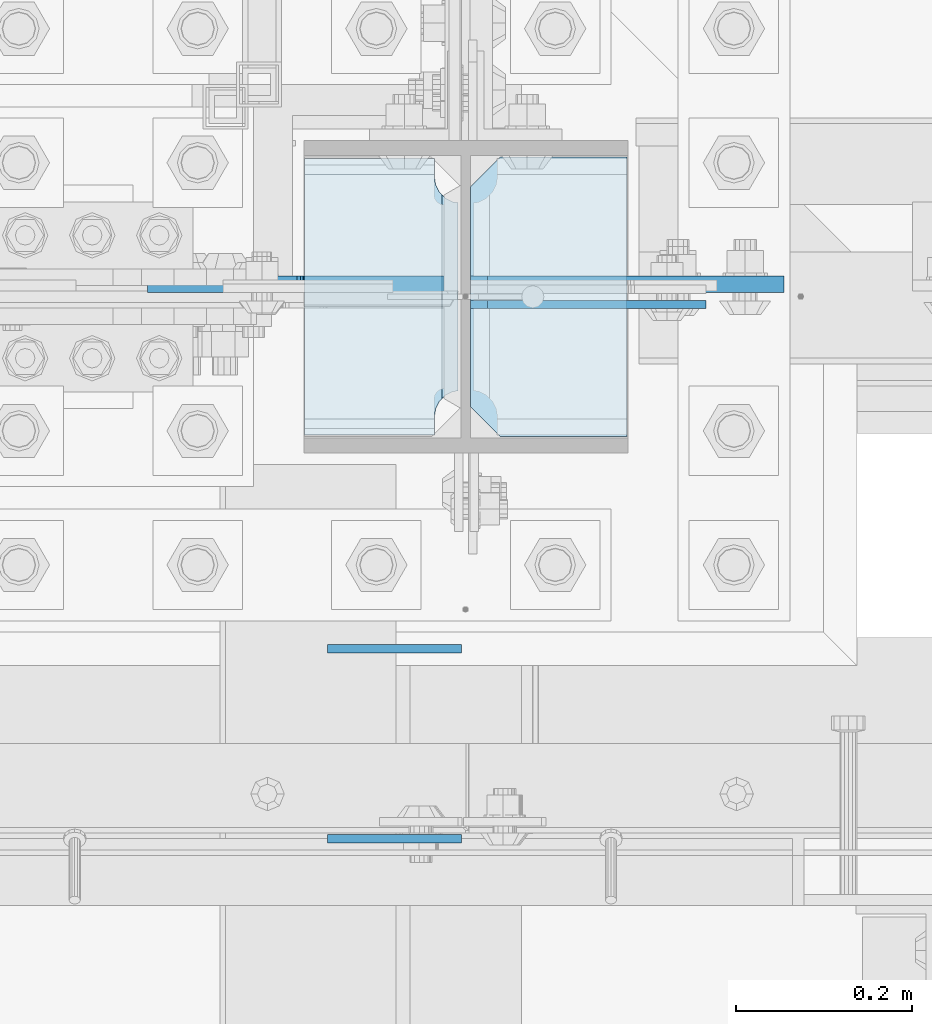
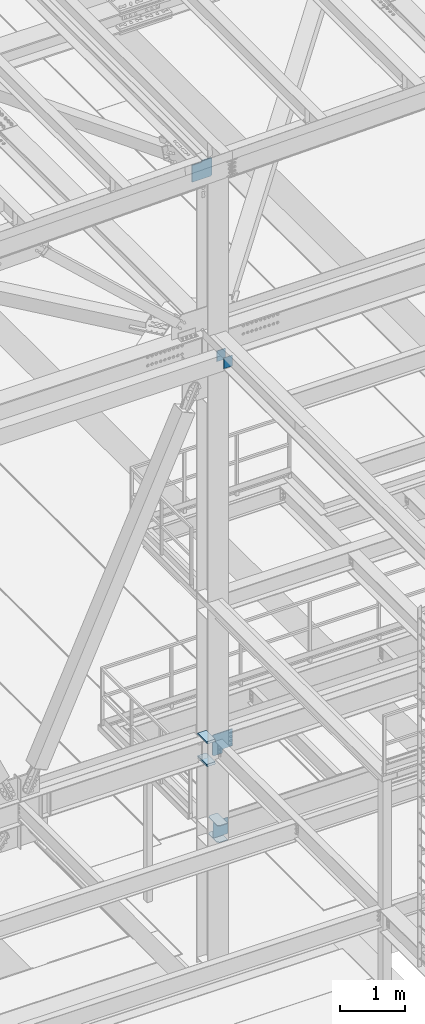
# One storey, part 3136 of 3843: 9 plates, 2 elements without a shape of their own.
"""IFC2X3 building model written with IfcOpenShell, lengths in millimetres."""

import ifcopenshell
import ifcopenshell.guid

model = None  # the IFC model being written
_history = None  # IfcOwnerHistory: only IFC2X3 demands one
_inside = {}  # id of a spatial element -> (the spatial element, [elements in it])
_under = {}  # id of a project, library or spatial element -> (it, [spatial elements below it])
_declared = {}  # id of a project -> (the project, [libraries it declares])
_typed = {}  # id of a type object -> (the type object, [elements of that type])
_made_of = {}  # id of a material, layer set ... -> (it, [elements and type objects made of it])


def new_model(schema):
    """Start an empty IFC model of exactly this schema.

    Asked for "IFC4X3", IfcOpenShell would pick the latest addendum, in which some entities
    have other attributes; the version numbers below select the first issue.
    IFC2X3 requires an IfcOwnerHistory on every rooted entity: one is made here for all.
    """
    global model, _history
    if schema == "IFC4X3":
        model = ifcopenshell.file(schema_version=(4, 3, 0, 0))
    else:
        model = ifcopenshell.file(schema=schema)
    _inside.clear()
    _under.clear()
    _declared.clear()
    _typed.clear()
    _made_of.clear()
    _history = None
    if model.schema == "IFC2X3":
        org = make("IfcOrganization", Name="unknown")
        user = make(
            "IfcPersonAndOrganization",
            ThePerson=make("IfcPerson", FamilyName="unknown"),
            TheOrganization=org,
        )
        app = make(
            "IfcApplication",
            ApplicationDeveloper=org,
            Version="unknown",
            ApplicationFullName="unknown",
            ApplicationIdentifier="unknown",
        )
        _history = make(
            "IfcOwnerHistory",
            OwningUser=user,
            OwningApplication=app,
            ChangeAction="ADDED",
            CreationDate=0,
        )
    return model


def make(cls, **values):
    """One entity of the class cls with the attributes given. An attribute that is None is left unset."""
    return model.create_entity(
        cls, **{name: value for name, value in values.items() if value is not None}
    )


def rooted(cls, **values):
    """An entity with a GlobalId (a new one), such as an element, a storey or a relation."""
    return make(cls, GlobalId=ifcopenshell.guid.new(), OwnerHistory=_history, **values)


def si_unit(unit_type, name, prefix=None):
    """IfcSIUnit, for example si_unit("LENGTHUNIT", "METRE", prefix="MILLI")."""
    return make("IfcSIUnit", UnitType=unit_type, Prefix=prefix, Name=name)


def assignment(units):
    """IfcUnitAssignment: the units of a project."""
    return None if units is None else make("IfcUnitAssignment", Units=units)


def point(xyz):
    """IfcCartesianPoint."""
    return None if xyz is None else make("IfcCartesianPoint", Coordinates=xyz)


def direction(xyz):
    """IfcDirection."""
    return None if xyz is None else make("IfcDirection", DirectionRatios=xyz)


def frame(location, z_axis=None, x_axis=None):
    """IfcAxis2Placement3D, a coordinate frame: its origin and axes. An axis left out is left unset."""
    return make(
        "IfcAxis2Placement3D",
        Location=point(location),
        Axis=direction(z_axis),
        RefDirection=direction(x_axis),
    )


def origin_with_axes():
    """The frame at (0, 0, 0) with the z axis (0, 0, 1) and the x axis (1, 0, 0) written out."""
    return frame((0.0, 0.0, 0.0), z_axis=(0.0, 0.0, 1.0), x_axis=(1.0, 0.0, 0.0))


def place(relative_to, where):
    """IfcLocalPlacement: puts the frame where relative to a parent placement (None: the world)."""
    return make(
        "IfcLocalPlacement", PlacementRelTo=relative_to, RelativePlacement=where
    )


def context(
    kind, dimensions, precision=None, world=None, true_north=None, identifier=None
):
    """IfcGeometricRepresentationContext, for example the 3D "Model" context."""
    return make(
        "IfcGeometricRepresentationContext",
        ContextIdentifier=identifier,
        ContextType=kind,
        CoordinateSpaceDimension=dimensions,
        Precision=precision,
        WorldCoordinateSystem=world,
        TrueNorth=true_north,
    )


def subcontext(parent, identifier, kind, view, scale=None):
    """IfcGeometricRepresentationSubContext, for example "Body" below "Model"."""
    return make(
        "IfcGeometricRepresentationSubContext",
        ContextIdentifier=identifier,
        ContextType=kind,
        ParentContext=parent,
        TargetScale=scale,
        TargetView=view,
    )


def project(units=None, contexts=None):
    """IfcProject with its units and contexts."""
    return rooted(
        "IfcProject",
        Name="project",
        RepresentationContexts=contexts,
        UnitsInContext=assignment(units),
    )


def spatial(cls, under=None, at=None, **own):
    """A site, building, storey or space (cls), placed at a placement, below another one or the project."""
    s = rooted(cls, ObjectPlacement=at, **own)
    if under is not None:
        _under.setdefault(under.id(), (under, []))[1].append(s)
    return s


def faces_of(points, faces, orient=None, outer=None):
    """IfcFace entities. A face is a list of loops; a loop is a list of indices into points, from 0.

    orient and outer hold one flag for each loop. By default every Orientation is true, the
    first loop of a face is its IfcFaceOuterBound and the others are IfcFaceBound.
    """
    made = []
    for i, loops in enumerate(faces):
        bounds = []
        for j, loop in enumerate(loops):
            is_outer = j == 0 if outer is None else outer[i][j]
            bounds.append(
                make(
                    "IfcFaceOuterBound" if is_outer else "IfcFaceBound",
                    Bound=make("IfcPolyLoop", Polygon=[points[k] for k in loop]),
                    Orientation=True if orient is None else orient[i][j],
                )
            )
        made.append(make("IfcFace", Bounds=bounds))
    return made


def faceted_brep(points, faces, orient=None, outer=None, voids=None):
    """IfcFacetedBrep: a solid bounded by flat faces; with voids (closed shells), ...WithVoids."""
    shared = [point(p) for p in points]
    hull = make("IfcClosedShell", CfsFaces=faces_of(shared, faces, orient, outer))
    if voids is None:
        return make("IfcFacetedBrep", Outer=hull)
    return make(
        "IfcFacetedBrepWithVoids",
        Outer=hull,
        Voids=[
            make(cls, CfsFaces=faces_of(shared, fs, o, b)) for cls, fs, o, b in voids
        ],
    )


def shape(context_of_items, identifier, shape_type, items):
    """IfcShapeRepresentation: the items that make up one representation, for example the "Body"."""
    return make(
        "IfcShapeRepresentation",
        ContextOfItems=context_of_items,
        RepresentationIdentifier=identifier,
        RepresentationType=shape_type,
        Items=items,
    )


def material(Name=None, Category=None):
    """IfcMaterial."""
    return make("IfcMaterial", Name=Name, Category=Category)


def made_of(thing, what):
    """Note that an element or type object is made of a material, layer set ...; save() writes the relation."""
    if what is not None:
        _made_of.setdefault(what.id(), (what, []))[1].append(thing)
    return thing


def type_object(cls, material=None, **own):
    """A type object (cls), such as IfcWallType, which elements share."""
    return made_of(rooted(cls, **own), material)


def element(
    cls,
    number,
    at=None,
    inside=None,
    cuts=None,
    type_object=None,
    material=None,
    context=None,
    identifier="Body",
    shape_type=None,
    held_by="IfcProductDefinitionShape",
    body=None,
    shapes=None,
    **own,
):
    """One element of the class cls, such as IfcWall. Its Tag is "e" and its number.

    at: its placement. inside: the storey or other place that contains it. cuts: it is an
    opening in that element (IfcRelVoidsElement). A single representation is given by context,
    identifier, shape_type and body (its items); several are given by shapes. held_by: the class
    of the entity that holds the representations. save() writes the other relations.
    """
    e = rooted(cls, Tag="e%d" % number, ObjectPlacement=at, **own)
    if body is not None:
        shapes = [shape(context, identifier, shape_type, body)]
    if shapes is not None:
        e.Representation = make(held_by, Representations=shapes)
    if inside is not None:
        _inside.setdefault(inside.id(), (inside, []))[1].append(e)
    if cuts is not None:
        rooted(
            "IfcRelVoidsElement", RelatingBuildingElement=cuts, RelatedOpeningElement=e
        )
    if type_object is not None:
        _typed.setdefault(type_object.id(), (type_object, []))[1].append(e)
    return made_of(e, material)


def aggregate(whole, parts):
    """IfcRelAggregates: a whole, such as a stair, and the parts it consists of."""
    return rooted("IfcRelAggregates", RelatingObject=whole, RelatedObjects=parts)


def save(model, path):
    """Write the relations noted so far, then the file.

    IfcRelAggregates (storeys below a building ...), IfcRelContainedInSpatialStructure (elements
    in a storey), IfcRelDefinesByType, IfcRelAssociatesMaterial and IfcRelDeclares: one each for
    every whole, place, type object, material and project.
    """
    for whole, parts in _under.values():
        aggregate(whole, parts)
    for where, things in _inside.values():
        rooted(
            "IfcRelContainedInSpatialStructure",
            RelatedElements=things,
            RelatingStructure=where,
        )
    for kind, things in _typed.values():
        rooted("IfcRelDefinesByType", RelatedObjects=things, RelatingType=kind)
    for what, things in _made_of.values():
        rooted("IfcRelAssociatesMaterial", RelatedObjects=things, RelatingMaterial=what)
    for by, libraries in _declared.values():
        rooted("IfcRelDeclares", RelatingContext=by, RelatedDefinitions=libraries)
    model.write(path)


model = new_model("IFC2X3")

# Units and contexts
model_context = context("Model", 3, precision=1e-05, world=origin_with_axes())
body_context = subcontext(model_context, "Body", "Model", "MODEL_VIEW")
ifc_project = project(units=[si_unit("LENGTHUNIT", "METRE", prefix="MILLI"), si_unit("AREAUNIT", "SQUARE_METRE"), si_unit("VOLUMEUNIT", "CUBIC_METRE"), si_unit("MASSUNIT", "GRAM", prefix="KILO"), si_unit("TIMEUNIT", "SECOND"), si_unit("PLANEANGLEUNIT", "RADIAN"), si_unit("SOLIDANGLEUNIT", "STERADIAN"), si_unit("THERMODYNAMICTEMPERATUREUNIT", "DEGREE_CELSIUS"), si_unit("LUMINOUSINTENSITYUNIT", "LUMEN")], contexts=[model_context])

# Site, building, storey
site_placement = place(None, origin_with_axes())
site = spatial("IfcSite", under=ifc_project, at=site_placement, CompositionType="ELEMENT")
building_placement = place(site_placement, origin_with_axes())
building = spatial("IfcBuilding", under=site, at=building_placement, Name="Undefined", CompositionType="ELEMENT")
storey_placement = place(building_placement, origin_with_axes())
storey = spatial("IfcBuildingStorey", under=building, at=storey_placement, Name="Undefined", CompositionType="ELEMENT", Elevation=0.0)

# Assembly, plates
assembly_1_placement = place(storey_placement, origin_with_axes())
assembly_1 = element("IfcElementAssembly", 1, at=assembly_1_placement, inside=storey, Name="COLUMN", AssemblyPlace="NOTDEFINED", PredefinedType="RIGID_FRAME")
ifc_material = material(Name="STEEL/A572-50")
plate_type_1 = type_object("IfcPlateType", PredefinedType="NOTDEFINED")
plate_1_placement = place(assembly_1_placement, frame((49179.95625, 25457.15, 32850.1375), z_axis=(0.0, 1.0, 0.0), x_axis=(-1.0, 0.0, 0.0)))
plate_1 = element("IfcPlate", 2, at=plate_1_placement, type_object=plate_type_1, material=ifc_material, Name="PLATE", context=body_context, shape_type="Brep", body=[
    faceted_brep([(0.0, -4.76249999999709, 0.0), (0.0, -4.76249999785796, 317.500000005042), (0.0, 4.76250000210712, 317.50000000505), (0.0, 4.76249999999709, 0.0), (144.462501525879, -4.76249999999709, 317.5), (144.462501525879, 4.76249999999709, 317.5), (177.800003051758, -4.76249999999709, 284.162498474121), (177.800003051758, 4.76249999999709, 284.162498474121), (177.800003051758, -4.76249999999709, 33.3375015258789), (177.800003051758, 4.76249999999709, 33.3375015258789), (144.462501525879, -4.76249999999709, 0.0), (144.462501525879, 4.76249999999709, 0.0)], [[[0, 1, 2, 3]], [[1, 4, 5, 2]], [[4, 6, 7, 5]], [[6, 8, 9, 7]], [[8, 10, 11, 9]], [[10, 0, 3, 11]], [[5, 7, 9, 11, 3, 2]], [[10, 8, 6, 4, 1, 0]]]),
])
plate_2_placement = place(assembly_1_placement, frame((49179.95625, 25457.15, 33164.4625), z_axis=(0.0, 1.0, 0.0), x_axis=(-1.0, 0.0, 0.0)))
plate_2 = element("IfcPlate", 3, at=plate_2_placement, type_object=plate_type_1, material=ifc_material, Name="PLATE", context=body_context, shape_type="Brep", body=[
    faceted_brep([(0.0, -4.76249999999709, 0.0), (0.0, -4.76249999785796, 317.500000005042), (0.0, 4.76250000210712, 317.50000000505), (0.0, 4.76249999999709, 0.0), (144.462501525879, -4.76249999999709, 317.5), (144.462501525879, 4.76249999999709, 317.5), (177.800003051758, -4.76249999999709, 284.162498474121), (177.800003051758, 4.76249999999709, 284.162498474121), (177.800003051758, -4.76249999999709, 33.3375015258789), (177.800003051758, 4.76249999999709, 33.3375015258789), (144.462501525879, -4.76249999999709, 0.0), (144.462501525879, 4.76249999999709, 0.0)], [[[0, 1, 2, 3]], [[1, 4, 5, 2]], [[4, 6, 7, 5]], [[6, 8, 9, 7]], [[8, 10, 11, 9]], [[10, 0, 3, 11]], [[5, 7, 9, 11, 3, 2]], [[10, 8, 6, 4, 1, 0]]]),
])
plate_type_2 = type_object("IfcPlateType", PredefinedType="NOTDEFINED")
plate_3_placement = place(assembly_1_placement, frame((48813.24375, 25776.2375, 34369.375), z_axis=(0.0, -1.0, 0.0), x_axis=(1.0, 0.0, 0.0)))
plate_3 = element("IfcPlate", 4, at=plate_3_placement, type_object=plate_type_2, material=ifc_material, Name="PLATE", context=body_context, shape_type="Brep", body=[
    faceted_brep([(160.070930155263, 9.33338851059671, 48.2144734940957), (156.294129000915, 15.875, 44.437675391513), (156.294129000915, 15.875, 276.23732460849), (160.070930155263, 9.33338851059671, 272.460514298873), (168.479277841041, -5.23029688887618, 268.176247164767), (174.625000047687, -15.875, 267.202872116366), (174.625000047687, -15.875, 53.4721278836369), (168.479277841041, -5.23029688887618, 52.4987406282016), (147.637499618526, 15.875, 21.5063709990791), (147.637499618526, -15.875, 3.17549995230729), (0.0, -15.875, 3.17549995230729), (0.0, 15.875, 21.5063709990791), (0.0, 15.875, 299.169629000906), (0.0, -15.875, 317.500500047678), (147.637499618526, -15.875, 317.500500047678), (147.637499618526, 15.875, 299.169629000906), (147.63749961853, -15.875, 296.862501907352), (147.63749961853, 15.875, 296.862501907352), (149.113757464445, -15.875, 287.541776696642), (149.113757464445, 15.875, 287.541776696642), (153.398024598548, -15.875, 279.133429010864), (153.398024598548, 15.875, 279.133429010864), (160.070927103505, -15.875, 272.460526505907), (168.479274789282, -15.875, 268.176259371801), (168.479274789282, -15.875, 52.4987406282016), (160.070927103505, -15.875, 48.2144734940957), (153.398024598548, -15.875, 41.5415709891386), (153.398024598548, 15.875, 41.5415709891386), (149.113757464449, -15.875, 33.1332233033609), (149.113757464449, 15.875, 33.1332233033609), (147.63749961853, -15.875, 23.8124980926514), (147.63749961853, 15.875, 23.8124980926514)], [[[0, 1, 2, 3, 4, 5, 6, 7]], [[8, 9, 10, 11]], [[12, 13, 14, 15]], [[13, 12, 11, 10]], [[16, 17, 15, 14]], [[16, 18, 19, 17]], [[18, 20, 21, 19]], [[21, 20, 22, 3, 2]], [[22, 23, 4, 3]], [[23, 5, 4]], [[24, 7, 6]], [[24, 25, 0, 7]], [[25, 26, 27, 1, 0]], [[26, 28, 29, 27]], [[28, 30, 31, 29]], [[31, 30, 9, 8]], [[27, 29, 31, 8, 11, 12, 15, 17, 19, 21, 2, 1]], [[9, 30, 28, 26, 25, 24, 6, 5, 23, 22, 20, 18, 16, 14, 13, 10]]]),
])
plate_4_placement = place(assembly_1_placement, frame((48813.24375, 25776.2375, 34794.825), z_axis=(0.0, -1.0, 0.0), x_axis=(1.0, 0.0, 0.0)))
plate_4 = element("IfcPlate", 5, at=plate_4_placement, type_object=plate_type_2, material=ifc_material, Name="PLATE", context=body_context, shape_type="Brep", body=[
    faceted_brep([(160.070930155263, 9.33338851059671, 48.2144734940957), (156.294129000915, 15.875, 44.437675391513), (156.294129000915, 15.875, 276.23732460849), (160.070930155263, 9.33338851059671, 272.460514298873), (168.479277841041, -5.23029688887618, 268.176247164767), (174.625000047687, -15.875, 267.202872116366), (174.625000047687, -15.875, 53.4721278836369), (168.479277841041, -5.23029688887618, 52.4987406282016), (147.637499618526, 15.875, 21.5063709990791), (147.637499618526, -15.875, 3.17549995230729), (0.0, -15.875, 3.17549995230729), (0.0, 15.875, 21.5063709990791), (0.0, 15.875, 299.169629000906), (0.0, -15.875, 317.500500047678), (147.637499618526, -15.875, 317.500500047678), (147.637499618526, 15.875, 299.169629000906), (147.63749961853, -15.875, 296.862501907352), (147.63749961853, 15.875, 296.862501907352), (149.113757464445, -15.875, 287.541776696642), (149.113757464445, 15.875, 287.541776696642), (153.398024598548, -15.875, 279.133429010864), (153.398024598548, 15.875, 279.133429010864), (160.070927103505, -15.875, 272.460526505907), (168.479274789282, -15.875, 268.176259371801), (168.479274789282, -15.875, 52.4987406282016), (160.070927103505, -15.875, 48.2144734940957), (153.398024598548, -15.875, 41.5415709891386), (153.398024598548, 15.875, 41.5415709891386), (149.113757464449, -15.875, 33.1332233033609), (149.113757464449, 15.875, 33.1332233033609), (147.63749961853, -15.875, 23.8124980926514), (147.63749961853, 15.875, 23.8124980926514)], [[[0, 1, 2, 3, 4, 5, 6, 7]], [[8, 9, 10, 11]], [[12, 13, 14, 15]], [[13, 12, 11, 10]], [[16, 17, 15, 14]], [[16, 18, 19, 17]], [[18, 20, 21, 19]], [[21, 20, 22, 3, 2]], [[22, 23, 4, 3]], [[23, 5, 4]], [[24, 7, 6]], [[24, 25, 0, 7]], [[25, 26, 27, 1, 0]], [[26, 28, 29, 27]], [[28, 30, 31, 29]], [[31, 30, 9, 8]], [[27, 29, 31, 8, 11, 12, 15, 17, 19, 21, 2, 1]], [[9, 30, 28, 26, 25, 24, 6, 5, 23, 22, 20, 18, 16, 14, 13, 10]]]),
])

assembly_2_placement = place(storey_placement, origin_with_axes())
assembly_2 = element("IfcElementAssembly", 6, at=assembly_2_placement, inside=storey, Name="BEAM", AssemblyPlace="NOTDEFINED", PredefinedType="RIGID_FRAME")
plate_type_3 = type_object("IfcPlateType", PredefinedType="NOTDEFINED")
plate_5_placement = place(assembly_2_placement, frame((48991.8375000001, 25215.85, 42316.3999992372), z_axis=(0.0, 0.0, -1.0), x_axis=(-1.0, 0.0, 0.0)))
plate_5 = element("IfcPlate", 7, at=plate_5_placement, type_object=plate_type_3, material=ifc_material, Name="PLATE", context=body_context, shape_type="Brep", body=[
    faceted_brep([(0.0, -4.76249999999709, 0.0), (0.0, -4.76250000000073, 203.199996948242), (0.0, 4.76250000000073, 203.199996948242), (0.0, 4.76249999999709, 0.0), (152.399993896484, -4.76250000000073, 203.199996948242), (152.399993896484, 4.76250000000073, 203.199996948242), (152.399993896484, -4.76249999999709, 0.0), (152.399993896484, 4.76249999999709, 0.0)], [[[0, 1, 2, 3]], [[1, 4, 5, 2]], [[4, 6, 7, 5]], [[6, 0, 3, 7]], [[5, 7, 3, 2]], [[6, 4, 1, 0]]]),
])
plate_6_placement = place(assembly_2_placement, frame((48991.8375000001, 24999.95, 42316.3999992372), z_axis=(0.0, 0.0, -1.0), x_axis=(-1.0, 0.0, 0.0)))
plate_6 = element("IfcPlate", 8, at=plate_6_placement, type_object=plate_type_3, material=ifc_material, Name="PLATE", context=body_context, shape_type="Brep", body=[
    faceted_brep([(0.0, -4.76249999999709, 0.0), (0.0, -4.76250000000073, 203.199996948242), (0.0, 4.76250000000073, 203.199996948242), (0.0, 4.76249999999709, 0.0), (152.399993896484, -4.76250000000073, 203.199996948242), (152.399993896484, 4.76250000000073, 203.199996948242), (152.399993896484, -4.76249999999709, 0.0), (152.399993896484, 4.76249999999709, 0.0)], [[[0, 1, 2, 3]], [[1, 4, 5, 2]], [[4, 6, 7, 5]], [[6, 0, 3, 7]], [[5, 7, 3, 2]], [[6, 4, 1, 0]]]),
])
aggregate(assembly_2, [plate_5, plate_6])

# Plate
plate_type_4 = type_object("IfcPlateType", PredefinedType="NOTDEFINED")
plate_7_placement = place(assembly_1_placement, frame((49002.15625, 25630.1875003815, 34404.3), z_axis=(0.707106781186548, 0.0, 0.707106781186548), x_axis=(0.707106781186548, 0.0, -0.707106781186548)))
plate_7 = element("IfcPlate", 9, at=plate_7_placement, type_object=plate_type_4, material=ifc_material, Name="PLATE", context=body_context, shape_type="Brep", body=[
    faceted_brep([(0.0, -9.52500000000146, 0.0), (-251.447171388727, -9.52500000000146, 251.447171388732), (-251.447171388727, 9.52500000000146, 251.447171388732), (0.0, 9.52500000000146, 0.0), (-251.447171388727, -9.52500000000146, 278.387939751803), (-251.447171388727, 9.52500000000146, 278.387939751803), (-12.9091181739805, -9.52500000000146, 516.92599296655), (-12.9091181739805, 9.52500000000146, 516.92599296655), (211.59728485167, -9.52500000000146, 292.419589940895), (211.59728485167, 9.52500000000146, 292.419589940895), (94.8539551434897, -9.52500000000146, 175.676260232722), (94.8539551434897, 9.52500000000146, 175.676260232722), (92.1009412430158, -9.52500000000146, 171.556083764575), (92.1009412430158, 9.52500000000146, 171.556083764575), (91.1342113204319, -9.52500000000146, 166.696004246536), (91.1342113204319, 9.52500000000146, 166.696004246536), (92.1009412430158, -9.52500000000146, 161.835924728512), (92.1009412430158, 9.52500000000146, 161.835924728512), (94.8539551434824, -9.52500000000146, 157.715748260365), (94.8539551434824, 9.52500000000146, 157.715748260365), (139.755236456211, -9.52500000000146, 112.814466211697), (139.755236456211, 9.52500000000146, 112.814466211697), (26.9407683632344, -9.52499999999964, 2.03726813197136e-10), (26.9407683632344, 9.52499999999964, 2.03726813197136e-10)], [[[0, 1, 2, 3]], [[1, 4, 5, 2]], [[4, 6, 7, 5]], [[6, 8, 9, 7]], [[8, 10, 11, 9]], [[10, 12, 13, 11]], [[12, 14, 15, 13]], [[14, 16, 17, 15]], [[16, 18, 19, 17]], [[18, 20, 21, 19]], [[20, 22, 23, 21]], [[22, 0, 3, 23]], [[5, 7, 9, 11, 13, 15, 17, 19, 21, 23, 3, 2]], [[22, 20, 18, 16, 14, 12, 10, 8, 6, 4, 1, 0]]]),
])

plate_type_5 = type_object("IfcPlateType", PredefinedType="NOTDEFINED")
plate_8_placement = place(assembly_1_placement, frame((48991.04375, 25630.1875003815, 45332.4102447497), z_axis=(-0.707106781186548, 0.0, 0.707106781186548), x_axis=(-0.707106781186548, 0.0, -0.707106781186548)))
plate_8 = element("IfcPlate", 10, at=plate_8_placement, type_object=plate_type_5, material=ifc_material, Name="PLATE", context=body_context, shape_type="Brep", body=[
    faceted_brep([(0.0, -9.52500000000146, 0.0), (-217.83702560261, -9.52500000000146, 217.837025602606), (-217.83702560261, 9.52500000000146, 217.837025602606), (0.0, 9.52500000000146, 0.0), (-217.837025602319, -9.52500000000146, 244.777793965968), (-217.837025602319, 9.52500000000146, 244.777793965968), (-105.02255807961, -9.52500000000146, 357.592261488677), (-105.02255807961, 9.52500000000146, 357.592261488677), (-94.254791630985, -9.52500000000146, 346.824495040062), (-94.254791630985, 9.52500000000146, 346.824495040062), (-90.1346151628532, -9.52500000000146, 344.071481139596), (-90.1346151628532, 9.52500000000146, 344.071481139596), (-85.2745356447995, -9.52500000000146, 343.104751217026), (-85.2745356447995, 9.52500000000146, 343.104751217026), (-80.4144561267167, -9.52500000000146, 344.07148113965), (-80.4144561267167, 9.52500000000146, 344.07148113965), (-76.2942796585558, -9.52500000000146, 346.824495040149), (-76.2942796585558, 9.52500000000146, 346.824495040149), (40.4490500521206, -9.52500000000146, 463.567824750826), (40.4490500521206, 9.52500000000146, 463.567824750826), (264.955453077768, -9.52500000000146, 239.061421725179), (264.955453077768, 9.52500000000146, 239.061421725179), (26.9407683632344, -9.52499999999964, 2.03726813197136e-10), (26.9407683632344, 9.52499999999964, 2.03726813197136e-10)], [[[0, 1, 2, 3]], [[1, 4, 5, 2]], [[4, 6, 7, 5]], [[6, 8, 9, 7]], [[8, 10, 11, 9]], [[10, 12, 13, 11]], [[12, 14, 15, 13]], [[14, 16, 17, 15]], [[16, 18, 19, 17]], [[18, 20, 21, 19]], [[20, 22, 23, 21]], [[22, 0, 3, 23]], [[5, 7, 9, 11, 13, 15, 17, 19, 21, 23, 3, 2]], [[22, 20, 18, 16, 14, 12, 10, 8, 6, 4, 1, 0]]]),
])

plate_type_6 = type_object("IfcPlateType", PredefinedType="NOTDEFINED")
plate_9_placement = place(assembly_1_placement, frame((49002.15625, 25607.16875, 32873.9500026613), z_axis=(0.707106781186548, 0.0, 0.707106781186548), x_axis=(0.707106781186548, 0.0, -0.707106781186548)))
plate_9 = element("IfcPlate", 11, at=plate_9_placement, type_object=plate_type_6, material=ifc_material, Name="PLATE", context=body_context, shape_type="Brep", body=[
    faceted_brep([(0.0, -4.76249999999709, 0.0), (-188.585379946875, -4.76249999999709, 188.585377136231), (-188.585379946875, 4.76249999999709, 188.585377136231), (0.0, 4.76249999999709, 0.0), (-188.585379946759, -4.76249999999709, 215.526145298725), (-188.585379946759, 4.76249999999709, 215.526145298725), (-12.9091160607786, -4.76250000000073, 391.202408440829), (-12.9091160607786, 4.76250000000073, 391.202408440829), (202.617028732588, -4.76249999999709, 175.676260369546), (202.617028732588, 4.76249999999709, 175.676260369546), (26.9407683631998, -4.76249999999709, 1.30967237055302e-10), (26.9407683631998, 4.76249999999709, 1.30967237055302e-10)], [[[0, 1, 2, 3]], [[1, 4, 5, 2]], [[4, 6, 7, 5]], [[6, 8, 9, 7]], [[8, 10, 11, 9]], [[10, 0, 3, 11]], [[5, 7, 9, 11, 3, 2]], [[10, 8, 6, 4, 1, 0]]]),
])

aggregate(assembly_1, [plate_8, plate_1, plate_2, plate_9, plate_7, plate_3, plate_4])

save(model, "model.ifc")
